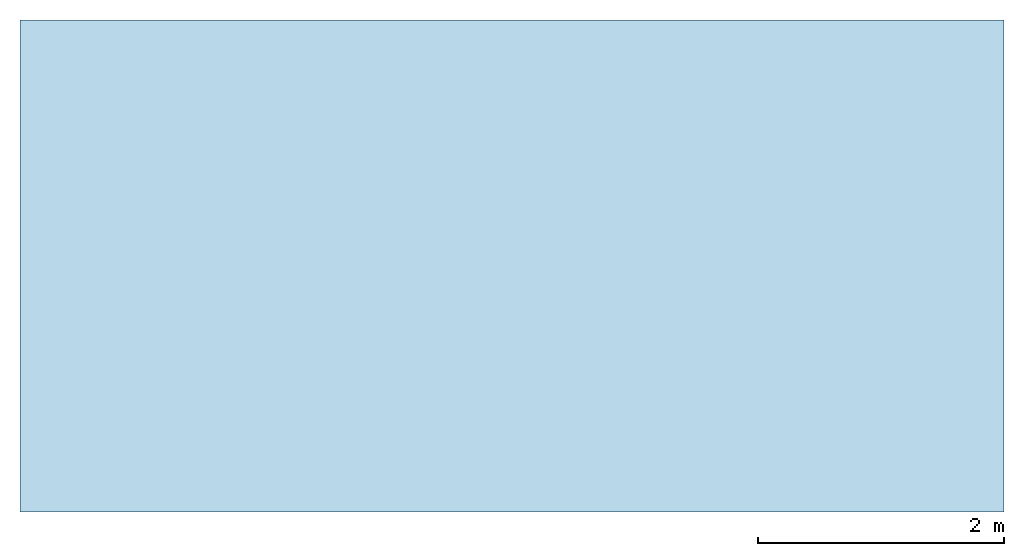
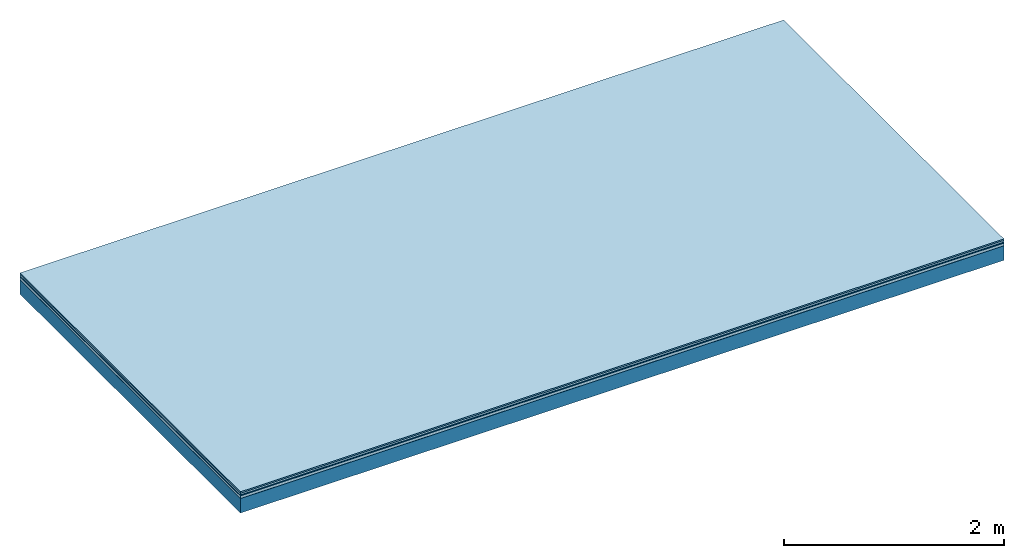
# One storey: 5 plates, 1 member, 1 element without a shape of its own.
"""IFC4 building model written with IfcOpenShell, lengths in metres."""

from ifc_helpers import new_model, si_unit, derived_unit, direction, frame, frame_2d, origin, origin_with_axes, place, context, project, spatial, rectangle, extrude, material, layer, layer_set, type_object, element, aggregate, save


model = new_model("IFC4")

# Units and contexts
plan_context = context("Plan", 3, precision=1e-05, world=origin(), true_north=direction((0.0, 1.0)))
model_context = context("Model", 3, precision=1e-05, world=origin(), true_north=direction((0.0, 1.0)))
ifc_project = project(units=[si_unit("LENGTHUNIT", "METRE"), derived_unit("SOUNDPRESSUREUNIT", [(si_unit("PRESSUREUNIT", "PASCAL", prefix="MICRO"), 0)]), si_unit("ENERGYUNIT", "JOULE", prefix="MEGA"), si_unit("MASSUNIT", "GRAM", prefix="KILO"), derived_unit("THERMALTRANSMITTANCEUNIT", [(si_unit("POWERUNIT", "WATT"), 1), (si_unit("AREAUNIT", "SQUARE_METRE"), -1), (si_unit("THERMODYNAMICTEMPERATUREUNIT", "KELVIN"), -1)]), derived_unit("AREADENSITYUNIT", [(si_unit("MASSUNIT", "GRAM", prefix="KILO"), 1), (si_unit("AREAUNIT", "SQUARE_METRE"), -1)]), derived_unit("USERDEFINED", [(si_unit("ENERGYUNIT", "JOULE", prefix="MEGA"), 1), (si_unit("AREAUNIT", "SQUARE_METRE"), -1)])], contexts=[plan_context, model_context])

# Site, building, storey
site = spatial("IfcSite", under=ifc_project)
building_placement = place(None, origin())
building = spatial("IfcBuilding", under=site, at=building_placement)
storey_placement = place(building_placement, origin())
storey = spatial("IfcBuildingStorey", under=building, at=storey_placement)

# Slab, member, plates
ifc_material_1 = material(Category="11.013")
ifc_layer_1 = layer(ifc_material_1, 0.015, Name="Flooring")
ifc_material_2 = material(Category="03.007")
ifc_layer_2 = layer(ifc_material_2, 0.02, Name="On-material")
ifc_material_3 = material(Name="Wood fiber generic product", Category="10.009")
ifc_layer_3 = layer(ifc_material_3, 0.01, Name="Impact sound insulation")
ifc_material_4 = material(Name="with broken")
ifc_layer_4 = layer(ifc_material_4, 0.03, Name="on Supporting structure")
ifc_material_5 = material(Name="protection", Category="09.007")
ifc_layer_5 = layer(ifc_material_5, 0.0005, Name="Sub-floor")
ifc_material_6 = material(Name="no composite action")
ifc_layer_6 = layer(ifc_material_6, 0.0, Name="Bond")
ifc_layer_7 = layer(None, 0.16, Name="Supporting structure")
ifc_layer_set = layer_set([ifc_layer_1, ifc_layer_2, ifc_layer_3, ifc_layer_4, ifc_layer_5, ifc_layer_6, ifc_layer_7])
slab_type = type_object("IfcSlabType", Name="A2044", PredefinedType="NOTDEFINED", material=ifc_layer_set)
slab_placement = place(None, frame((0.0, 0.0, 0.0), z_axis=(0.0, 0.0, -1.0), x_axis=(1.0, 0.0, 0.0)))
slab = element("IfcSlab", 1, at=slab_placement, inside=storey, type_object=slab_type, material=ifc_layer_set, Name="Slab #1")
ifc_material_7 = material(Name="Solid timber panel")
member_placement = place(slab_placement, origin())
member = element("IfcMember", 2, at=member_placement, material=ifc_material_7, Name="Supporting structure", context=plan_context, shape_type="SweptSolid", body=[
    extrude(rectangle(XDim=1.0, YDim=0.16, at=frame_2d((0.5, 0.08), x_axis=(1.0, 0.0))), frame((0.0, 4.0, 0.0755), z_axis=(0.0, -1.0, 0.0), x_axis=(1.0, 0.0, 0.0)), (0.0, 0.0, 1.0), 4.0),
    extrude(rectangle(XDim=1.0, YDim=0.16, at=frame_2d((0.5, 0.08), x_axis=(1.0, 0.0))), frame((1.0, 4.0, 0.0755), z_axis=(0.0, -1.0, 0.0), x_axis=(1.0, 0.0, 0.0)), (0.0, 0.0, 1.0), 4.0),
    extrude(rectangle(XDim=1.0, YDim=0.16, at=frame_2d((0.5, 0.08), x_axis=(1.0, 0.0))), frame((2.0, 4.0, 0.0755), z_axis=(0.0, -1.0, 0.0), x_axis=(1.0, 0.0, 0.0)), (0.0, 0.0, 1.0), 4.0),
    extrude(rectangle(XDim=1.0, YDim=0.16, at=frame_2d((0.5, 0.08), x_axis=(1.0, 0.0))), frame((3.0, 4.0, 0.0755), z_axis=(0.0, -1.0, 0.0), x_axis=(1.0, 0.0, 0.0)), (0.0, 0.0, 1.0), 4.0),
    extrude(rectangle(XDim=1.0, YDim=0.16, at=frame_2d((0.5, 0.08), x_axis=(1.0, 0.0))), frame((4.0, 4.0, 0.0755), z_axis=(0.0, -1.0, 0.0), x_axis=(1.0, 0.0, 0.0)), (0.0, 0.0, 1.0), 4.0),
    extrude(rectangle(XDim=1.0, YDim=0.16, at=frame_2d((0.5, 0.08), x_axis=(1.0, 0.0))), frame((5.0, 4.0, 0.0755), z_axis=(0.0, -1.0, 0.0), x_axis=(1.0, 0.0, 0.0)), (0.0, 0.0, 1.0), 4.0),
    extrude(rectangle(XDim=1.0, YDim=0.16, at=frame_2d((0.5, 0.08), x_axis=(1.0, 0.0))), frame((6.0, 4.0, 0.0755), z_axis=(0.0, -1.0, 0.0), x_axis=(1.0, 0.0, 0.0)), (0.0, 0.0, 1.0), 4.0),
    extrude(rectangle(XDim=1.0, YDim=0.16, at=frame_2d((0.5, 0.08), x_axis=(1.0, 0.0))), frame((7.0, 4.0, 0.0755), z_axis=(0.0, -1.0, 0.0), x_axis=(1.0, 0.0, 0.0)), (0.0, 0.0, 1.0), 4.0),
])
plate_1_placement = place(slab_placement, origin())
plate_1 = element("IfcPlate", 3, at=plate_1_placement, material=ifc_material_1, Name="Flooring", context=plan_context, shape_type="SweptSolid", body=[
    extrude(rectangle(XDim=8.0, YDim=4.0, at=frame_2d((4.0, 2.0), x_axis=(1.0, 0.0))), origin_with_axes(), (0.0, 0.0, 1.0), 0.015),
])
plate_2_placement = place(slab_placement, origin())
plate_2 = element("IfcPlate", 4, at=plate_2_placement, material=ifc_material_2, Name="On-material", context=plan_context, shape_type="SweptSolid", body=[
    extrude(rectangle(XDim=8.0, YDim=4.0, at=frame_2d((4.0, 2.0), x_axis=(1.0, 0.0))), frame((0.0, 0.0, 0.015), z_axis=(0.0, 0.0, 1.0), x_axis=(1.0, 0.0, 0.0)), (0.0, 0.0, 1.0), 0.02),
])
plate_3_placement = place(slab_placement, origin())
plate_3 = element("IfcPlate", 5, at=plate_3_placement, material=ifc_material_3, Name="Impact sound insulation", context=plan_context, shape_type="SweptSolid", body=[
    extrude(rectangle(XDim=8.0, YDim=4.0, at=frame_2d((4.0, 2.0), x_axis=(1.0, 0.0))), frame((0.0, 0.0, 0.035), z_axis=(0.0, 0.0, 1.0), x_axis=(1.0, 0.0, 0.0)), (0.0, 0.0, 1.0), 0.01),
])
plate_4_placement = place(slab_placement, origin())
plate_4 = element("IfcPlate", 6, at=plate_4_placement, material=ifc_material_4, Name="on Supporting structure", context=plan_context, shape_type="SweptSolid", body=[
    extrude(rectangle(XDim=8.0, YDim=4.0, at=frame_2d((4.0, 2.0), x_axis=(1.0, 0.0))), frame((0.0, 0.0, 0.045), z_axis=(0.0, 0.0, 1.0), x_axis=(1.0, 0.0, 0.0)), (0.0, 0.0, 1.0), 0.03),
])
plate_5_placement = place(slab_placement, origin())
plate_5 = element("IfcPlate", 7, at=plate_5_placement, material=ifc_material_5, Name="Sub-floor", context=plan_context, shape_type="SweptSolid", body=[
    extrude(rectangle(XDim=8.0, YDim=4.0, at=frame_2d((4.0, 2.0), x_axis=(1.0, 0.0))), frame((0.0, 0.0, 0.075), z_axis=(0.0, 0.0, 1.0), x_axis=(1.0, 0.0, 0.0)), (0.0, 0.0, 1.0), 0.0005),
])
aggregate(slab, [plate_1, plate_2, plate_3, plate_4, plate_5, member])

save(model, "model.ifc")
